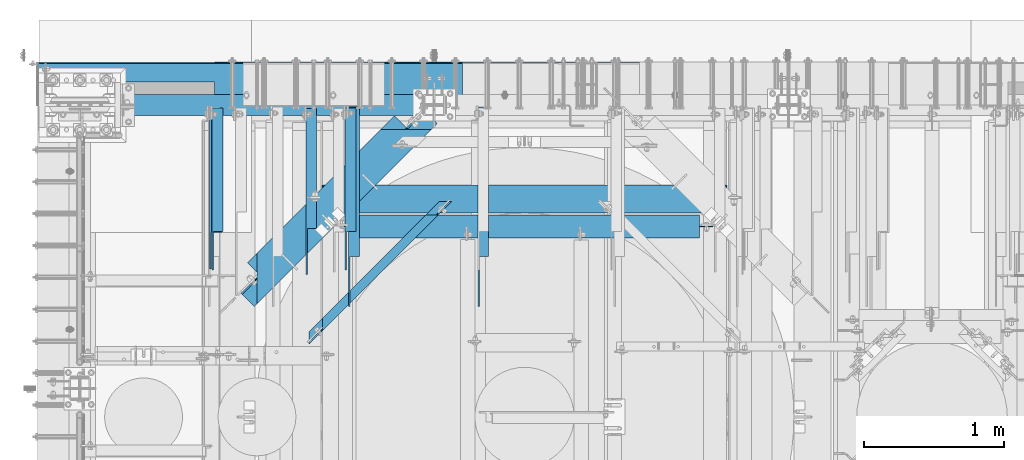
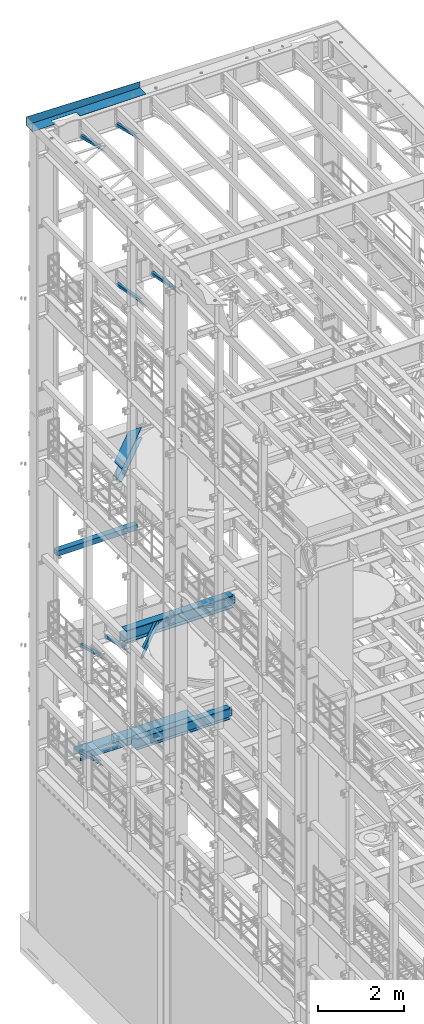
# One storey, part 1058 of 1876: 14 beams, 14 elements without a shape of their own.
"""IFC2X3 building model written with IfcOpenShell, lengths in millimetres."""

from ifc_helpers import new_model, si_unit, frame, origin_with_axes, place, context, subcontext, project, spatial, faceted_brep, material, type_object, element, aggregate, save


model = new_model("IFC2X3")

# Units and contexts
model_context = context("Model", 3, precision=1e-05, world=origin_with_axes())
body_context = subcontext(model_context, "Body", "Model", "MODEL_VIEW")
ifc_project = project(units=[si_unit("LENGTHUNIT", "METRE", prefix="MILLI"), si_unit("AREAUNIT", "SQUARE_METRE"), si_unit("VOLUMEUNIT", "CUBIC_METRE"), si_unit("MASSUNIT", "GRAM", prefix="KILO"), si_unit("TIMEUNIT", "SECOND"), si_unit("PLANEANGLEUNIT", "RADIAN"), si_unit("SOLIDANGLEUNIT", "STERADIAN"), si_unit("THERMODYNAMICTEMPERATUREUNIT", "DEGREE_CELSIUS"), si_unit("LUMINOUSINTENSITYUNIT", "LUMEN")], contexts=[model_context])

# Site, building, storey
site_placement = place(None, origin_with_axes())
site = spatial("IfcSite", under=ifc_project, at=site_placement, CompositionType="ELEMENT")
building_placement = place(site_placement, origin_with_axes())
building = spatial("IfcBuilding", under=site, at=building_placement, Name="Undefined", CompositionType="ELEMENT")
storey_placement = place(building_placement, origin_with_axes())
storey = spatial("IfcBuildingStorey", under=building, at=storey_placement, Name="Undefined", CompositionType="ELEMENT", Elevation=0.0)

# Assembly, beam
assembly_1_placement = place(storey_placement, origin_with_axes())
assembly_1 = element("IfcElementAssembly", 1, at=assembly_1_placement, inside=storey, Name="FRAME", AssemblyPlace="NOTDEFINED", PredefinedType="RIGID_FRAME")
ifc_material_1 = material()
beam_type_1 = type_object("IfcBeamType", Name="HSS6X6X3/8", PredefinedType="NOTDEFINED")
beam_1_placement = place(assembly_1_placement, frame((304.8, 13716.0, 10420.35), z_axis=(0.0, 1.0, 0.0), x_axis=(1.0, 0.0, 0.0)))
beam_1 = element("IfcBeam", 2, at=beam_1_placement, type_object=beam_type_1, material=ifc_material_1, Name="BEAM", ObjectType="HSS6X6X3/8", context=body_context, shape_type="Brep", body=[
    faceted_brep([(9.52500000000168, 66.6749999999993, -66.6750000000002), (9.52500000000168, -66.6749999999993, -66.6750000000002), (2159.0, -66.6750000000002, -66.6749999999993), (2159.0, 66.6750000000002, -66.6749999999993), (9.52500000000168, -66.6749999999993, 66.6750000000002), (2159.0, -66.6750000000002, 66.6749999999993), (9.52500000000168, 66.6749999999993, 66.6750000000002), (2159.0, 66.6750000000002, 66.6749999999993), (9.52500000000168, 76.2000000000007, -76.1999999999998), (9.52500000000168, 76.2000000000007, 76.1999999999998), (2159.0, 76.1999999999998, 76.2000000000007), (2159.0, 76.1999999999998, -76.2000000000007), (9.52500000000168, -76.2000000000007, 76.1999999999998), (2159.0, -76.1999999999998, 76.2000000000007), (9.52500000000168, -76.2000000000007, -76.1999999999998), (2159.0, -76.1999999999998, -76.2000000000007)], [[[0, 1, 2, 3]], [[1, 4, 5, 2]], [[4, 6, 7, 5]], [[6, 0, 3, 7]], [[8, 9, 10, 11]], [[9, 12, 13, 10]], [[12, 14, 15, 13]], [[14, 8, 11, 15]], [[13, 15, 11, 10], [5, 7, 3, 2]], [[14, 12, 9, 8], [6, 4, 1, 0]]]),
])
aggregate(assembly_1, [beam_1])

assembly_2_placement = place(storey_placement, origin_with_axes())
assembly_2 = element("IfcElementAssembly", 3, at=assembly_2_placement, inside=storey, AssemblyPlace="NOTDEFINED", PredefinedType="RIGID_FRAME")
ifc_material_2 = material(Name="STEEL/A36")
beam_type_2 = type_object("IfcBeamType", Name="L3X3X3/8", PredefinedType="NOTDEFINED")
beam_2_placement = place(assembly_2_placement, frame((968.375000095368, 12830.5843372416, 4789.15168871848), z_axis=(1.0, 0.0, 0.0), x_axis=(0.0, 0.967147277703794, -0.254216724922142)))
beam_2 = element("IfcBeam", 4, at=beam_2_placement, type_object=beam_type_2, material=ifc_material_2, ObjectType="L3X3X3/8", context=body_context, shape_type="Brep", body=[
    faceted_brep([(0.0, 38.1000000000004, -38.1), (0.0, 38.1000000000004, 38.1), (881.684520949349, 38.1000000001804, 38.1000000000004), (881.684520949349, 38.1000000001804, -38.1000000000004), (-36.2371036914428, 28.5749999999935, 38.1000000000004), (881.696433462228, 28.5750000001808, 38.1000000000004), (-36.2371036914428, 28.5749999999935, -28.5749999999998), (881.696433462228, 28.5750000001808, -28.5749999999998), (-289.896829504256, -38.1000000000595, -28.5749999999998), (881.779821052378, -38.0999999998203, -28.5749999999998), (-289.896829504256, -38.1000000000595, -38.1000000000004), (881.779821052378, -38.0999999998203, -38.1000000000004)], [[[0, 1, 2, 3]], [[1, 4, 5, 2]], [[4, 6, 7, 5]], [[6, 8, 9, 7]], [[8, 10, 11, 9]], [[10, 0, 3, 11]], [[5, 7, 9, 11, 3, 2]], [[10, 8, 6, 4, 1, 0]]]),
])
aggregate(assembly_2, [beam_2])

assembly_3_placement = place(storey_placement, origin_with_axes())
assembly_3 = element("IfcElementAssembly", 5, at=assembly_3_placement, inside=storey, AssemblyPlace="NOTDEFINED", PredefinedType="RIGID_FRAME")
beam_3_placement = place(assembly_3_placement, frame((1939.925, 12840.8509533049, 22213.431722183), z_axis=(1.0, 0.0, 0.0), x_axis=(0.0, 0.970296005691371, -0.241920774923053)))
beam_3 = element("IfcBeam", 6, at=beam_3_placement, type_object=beam_type_2, material=ifc_material_2, ObjectType="L3X3X3/8", context=body_context, shape_type="Brep", body=[
    faceted_brep([(0.0, 38.1000000000004, -38.1), (0.0, 38.1000000000004, 38.1), (871.989692018896, 38.1000000003733, 38.1000000000004), (871.989692018896, 38.1000000003733, -38.1000000000004), (-38.2028763666676, 28.5750000000298, 38.1000000000004), (871.9896920189, 28.5750000003572, 38.1000000000004), (-38.2028763666676, 28.5750000000298, -28.5749999999998), (871.9896920189, 28.5750000003572, -28.5749999999998), (-305.623010913256, -38.1000000001623, -28.5749999999998), (871.989692018928, -38.0999999997366, -28.5749999999998), (-305.623010913256, -38.1000000001623, -38.1000000000004), (871.989692018928, -38.0999999997366, -38.1000000000004)], [[[0, 1, 2, 3]], [[1, 4, 5, 2]], [[4, 6, 7, 5]], [[6, 8, 9, 7]], [[8, 10, 11, 9]], [[10, 0, 3, 11]], [[5, 7, 9, 11, 3, 2]], [[10, 8, 6, 4, 1, 0]]]),
])
aggregate(assembly_3, [beam_3])

assembly_4_placement = place(storey_placement, origin_with_axes())
assembly_4 = element("IfcElementAssembly", 7, at=assembly_4_placement, inside=storey, AssemblyPlace="NOTDEFINED", PredefinedType="RIGID_FRAME")
beam_4_placement = place(assembly_4_placement, frame((987.425, 12840.8509533049, 22213.431722183), z_axis=(1.0, 0.0, 0.0), x_axis=(0.0, 0.970296005691371, -0.241920774923053)))
beam_4 = element("IfcBeam", 8, at=beam_4_placement, type_object=beam_type_2, material=ifc_material_2, ObjectType="L3X3X3/8", context=body_context, shape_type="Brep", body=[
    faceted_brep([(0.0, 38.1000000000004, -38.1), (0.0, 38.1000000000004, 38.1), (871.989692018896, 38.1000000003733, 38.1000000000004), (871.989692018896, 38.1000000003733, -38.1000000000004), (-38.2028763666676, 28.5750000000298, 38.1000000000004), (871.9896920189, 28.5750000003572, 38.1000000000004), (-38.2028763666676, 28.5750000000298, -28.5749999999998), (871.9896920189, 28.5750000003572, -28.5749999999998), (-305.623010913256, -38.1000000001623, -28.5749999999998), (871.989692018928, -38.0999999997366, -28.5749999999998), (-305.623010913256, -38.1000000001623, -38.1000000000004), (871.989692018928, -38.0999999997366, -38.1000000000004)], [[[0, 1, 2, 3]], [[1, 4, 5, 2]], [[4, 6, 7, 5]], [[6, 8, 9, 7]], [[8, 10, 11, 9]], [[10, 0, 3, 11]], [[5, 7, 9, 11, 3, 2]], [[10, 8, 6, 4, 1, 0]]]),
])
aggregate(assembly_4, [beam_4])

assembly_5_placement = place(storey_placement, origin_with_axes())
assembly_5 = element("IfcElementAssembly", 9, at=assembly_5_placement, inside=storey, AssemblyPlace="NOTDEFINED", PredefinedType="RIGID_FRAME")
beam_5_placement = place(assembly_5_placement, frame((1659.73125, 12872.1857065717, 7766.82651976129), z_axis=(1.0, 0.0, 0.0), x_axis=(0.0, 0.979618903835331, -0.200865136966236)))
beam_5 = element("IfcBeam", 10, at=beam_5_placement, type_object=beam_type_2, material=ifc_material_2, ObjectType="L3X3X3/8", context=body_context, shape_type="Brep", body=[
    faceted_brep([(0.0, 38.1000000000004, -38.1), (0.0, 38.1000000000004, 38.1), (830.060116754295, 38.1000000001277, 38.0999999999999), (830.060116754295, 38.1000000001277, -38.0999999999999), (-46.4534075084157, 28.5749999999953, 38.0999999999999), (830.060116754288, 28.5750000001281, 38.0999999999999), (-46.4534075084157, 28.5749999999953, -28.575), (830.060116754288, 28.5750000001281, -28.575), (-371.627259972192, -38.1000000000549, -28.575), (830.060116754226, -38.0999999998749, -28.575), (-371.627259972192, -38.1000000000549, -38.0999999999999), (830.060116754226, -38.0999999998749, -38.0999999999999)], [[[0, 1, 2, 3]], [[1, 4, 5, 2]], [[4, 6, 7, 5]], [[6, 8, 9, 7]], [[8, 10, 11, 9]], [[10, 0, 3, 11]], [[5, 7, 9, 11, 3, 2]], [[10, 8, 6, 4, 1, 0]]]),
])
aggregate(assembly_5, [beam_5])

assembly_6_placement = place(storey_placement, origin_with_axes())
assembly_6 = element("IfcElementAssembly", 11, at=assembly_6_placement, inside=storey, AssemblyPlace="NOTDEFINED", PredefinedType="RIGID_FRAME")
beam_6_placement = place(assembly_6_placement, frame((981.075, 12830.5843372416, 7811.75168871848), z_axis=(1.0, 0.0, 0.0), x_axis=(0.0, 0.967147277703794, -0.254216724922142)))
beam_6 = element("IfcBeam", 12, at=beam_6_placement, type_object=beam_type_2, material=ifc_material_2, ObjectType="L3X3X3/8", context=body_context, shape_type="Brep", body=[
    faceted_brep([(0.0, 38.1000000000004, -38.1), (0.0, 38.1000000000004, 38.1), (881.684520949349, 38.1000000001804, 38.1000000000004), (881.684520949349, 38.1000000001804, -38.1000000000004), (-36.2371036914428, 28.5749999999935, 38.1000000000004), (881.696433462228, 28.5750000001808, 38.1000000000004), (-36.2371036914428, 28.5749999999935, -28.5749999999998), (881.696433462228, 28.5750000001808, -28.5749999999998), (-289.896829504256, -38.1000000000595, -28.5749999999998), (881.779821052378, -38.0999999998203, -28.5749999999998), (-289.896829504256, -38.1000000000595, -38.1000000000004), (881.779821052378, -38.0999999998203, -38.1000000000004)], [[[0, 1, 2, 3]], [[1, 4, 5, 2]], [[4, 6, 7, 5]], [[6, 8, 9, 7]], [[8, 10, 11, 9]], [[10, 0, 3, 11]], [[5, 7, 9, 11, 3, 2]], [[10, 8, 6, 4, 1, 0]]]),
])
aggregate(assembly_6, [beam_6])

assembly_7_placement = place(storey_placement, origin_with_axes())
assembly_7 = element("IfcElementAssembly", 13, at=assembly_7_placement, inside=storey, AssemblyPlace="NOTDEFINED", PredefinedType="RIGID_FRAME")
beam_7_placement = place(assembly_7_placement, frame((2892.425, 12478.7701585775, 17678.0584984364), z_axis=(1.0, 0.0, 0.0), x_axis=(0.0, 0.982729825630071, -0.185046182930343)))
beam_7 = element("IfcBeam", 14, at=beam_7_placement, type_object=beam_type_2, material=ifc_material_2, ObjectType="L3X3X3/8", context=body_context, shape_type="Brep", body=[
    faceted_brep([(200.493218531883, 38.099999999944, -38.1000000000004), (200.493218531883, 38.099999999944, 38.1000000000004), (1239.09835784596, 38.0999999993655, 38.1000000000004), (1239.09835784596, 38.0999999993655, -38.1000000000004), (149.908540475497, 28.5749999999571, 38.1000000000004), (1239.09863171315, 28.5749999993495, 38.1000000000004), (149.908540475497, 28.5749999999571, -28.5749999999998), (1239.09863171315, 28.5749999993495, -28.5749999999998), (-204.184205919202, -38.0999999999367, -28.5749999999998), (1239.10054878342, -38.1000000007407, -28.5749999999998), (-204.184205919202, -38.0999999999367, -38.1000000000004), (1239.10054878342, -38.1000000007407, -38.1000000000004)], [[[0, 1, 2, 3]], [[1, 4, 5, 2]], [[4, 6, 7, 5]], [[6, 8, 9, 7]], [[8, 10, 11, 9]], [[10, 0, 3, 11]], [[5, 7, 9, 11, 3, 2]], [[10, 8, 6, 4, 1, 0]]]),
])
aggregate(assembly_7, [beam_7])

assembly_8_placement = place(storey_placement, origin_with_axes())
assembly_8 = element("IfcElementAssembly", 15, at=assembly_8_placement, inside=storey, AssemblyPlace="NOTDEFINED", PredefinedType="RIGID_FRAME")
beam_8_placement = place(assembly_8_placement, frame((1965.325, 12478.7701585775, 17678.0584984364), z_axis=(1.0, 0.0, 0.0), x_axis=(0.0, 0.982729825630071, -0.185046182930343)))
beam_8 = element("IfcBeam", 16, at=beam_8_placement, type_object=beam_type_2, material=ifc_material_2, ObjectType="L3X3X3/8", context=body_context, shape_type="Brep", body=[
    faceted_brep([(200.493218531883, 38.099999999944, -38.1000000000004), (200.493218531883, 38.099999999944, 38.1000000000004), (1239.09835784596, 38.0999999993655, 38.1000000000004), (1239.09835784596, 38.0999999993655, -38.1000000000004), (149.908540475497, 28.5749999999571, 38.1000000000004), (1239.09863171315, 28.5749999993495, 38.1000000000004), (149.908540475497, 28.5749999999571, -28.5749999999998), (1239.09863171315, 28.5749999993495, -28.5749999999998), (-204.184205919202, -38.0999999999367, -28.5749999999998), (1239.10054878342, -38.1000000007407, -28.5749999999998), (-204.184205919202, -38.0999999999367, -38.1000000000004), (1239.10054878342, -38.1000000007407, -38.1000000000004)], [[[0, 1, 2, 3]], [[1, 4, 5, 2]], [[4, 6, 7, 5]], [[6, 8, 9, 7]], [[8, 10, 11, 9]], [[10, 0, 3, 11]], [[5, 7, 9, 11, 3, 2]], [[10, 8, 6, 4, 1, 0]]]),
])
aggregate(assembly_8, [beam_8])

assembly_9_placement = place(storey_placement, origin_with_axes())
assembly_9 = element("IfcElementAssembly", 17, at=assembly_9_placement, inside=storey, Name="BENT PLATE", AssemblyPlace="NOTDEFINED", PredefinedType="RIGID_FRAME")
beam_type_3 = type_object("IfcBeamType", PredefinedType="NOTDEFINED")
beam_9_placement = place(assembly_9_placement, frame((1219.2, 13715.9999771422, 22558.3750000001), z_axis=(1.0, 0.0, 0.0), x_axis=(0.0, 0.999999999968684, -7.91400000071008e-06)))
beam_9 = element("IfcBeam", 18, at=beam_9_placement, type_object=beam_type_3, material=ifc_material_2, Name="BENT PLATE", context=body_context, shape_type="Brep", body=[
    faceted_brep([(165.100051822586, -3.17500005137117, -927.100027859217), (165.100006108936, 3.17499994863465, -927.100027859217), (9.91349224932492e-10, 3.17500000000291, -927.100027859217), (-9.85892256721854e-10, -3.17500000000291, -927.100027859217), (165.100051822586, -3.17500005137117, -253.999991238123), (165.100006108936, 3.17499994863465, -253.999991238123), (-9.85892256721854e-10, -3.17500000000291, -253.999991238123), (9.91349224932492e-10, 3.17500000000291, -253.999991238123), (298.449951181141, 3.17499990714714, -1524.0), (298.449951181141, 3.17499990714714, 1524.0), (298.448968570774, 173.680054702585, 1524.0), (298.448604036646, 236.934945778212, -1524.0), (-9.88620740827173e-10, 3.17500000000291, 1524.0), (9.877112461254e-10, -3.17499999999563, 1524.0), (304.799984389467, -3.1750000948341, 1524.0), (304.79896857062, 173.680100416237, 1524.0), (304.799984389467, -3.1750000948341, -1524.0), (304.798604036541, 236.934982372881, -1524.0), (9.877112461254e-10, -3.17499999999563, -1524.0), (-9.88620740827173e-10, 3.17500000000291, -1524.0)], [[[0, 1, 2, 3]], [[4, 5, 1, 0]], [[6, 7, 5, 4]], [[8, 9, 10, 11]], [[9, 12, 13, 14, 15, 10]], [[14, 16, 17, 15]], [[11, 10, 15, 17]], [[16, 18, 19, 8, 11, 17]], [[19, 18, 3, 2]], [[12, 9, 8, 19, 2, 1, 5, 7]], [[13, 12, 7, 6]], [[3, 18, 16, 14, 13, 6, 4, 0]]]),
])
aggregate(assembly_9, [beam_9])

assembly_10_placement = place(storey_placement, origin_with_axes())
assembly_10 = element("IfcElementAssembly", 19, at=assembly_10_placement, inside=storey, Name="BENT PLATE", AssemblyPlace="NOTDEFINED", PredefinedType="RIGID_FRAME")
beam_type_4 = type_object("IfcBeamType", PredefinedType="NOTDEFINED")
beam_10_placement = place(assembly_10_placement, frame((2489.20001220703, 14017.625, 4279.90000305174), z_axis=(1.0, 0.0, 0.0), x_axis=(0.0, 0.0, 1.0)))
beam_10 = element("IfcBeam", 20, at=beam_10_placement, type_object=beam_type_4, material=ifc_material_2, Name="BENT PLATE", context=body_context, shape_type="Brep", body=[
    faceted_brep([(0.0, -6.35000000000036, -1524.0), (0.0, -6.35000000000036, 1524.0), (0.0, 6.35000000000036, 1524.0), (0.0, 6.35000000000036, -1524.0), (190.499996948255, 6.35000000000218, 1524.0), (190.499996948255, 6.35000000000218, -1524.0), (203.199996948256, -6.34999999999854, -1524.0), (203.199996948256, -6.34999999999854, 1524.0), (190.499996948255, 303.212481689452, 1524.0), (190.499996948255, 303.212481689452, -1524.0), (203.199996948256, 315.912481689453, -1524.0), (203.199996948256, 315.912481689453, 1524.0), (2.81943357549608e-11, 303.212481689452, 1524.0), (2.81943357549608e-11, 303.212481689452, -1524.0), (2.81943357549608e-11, 315.912481689453, 1524.0), (2.81943357549608e-11, 315.912481689453, -1524.0)], [[[0, 1, 2, 3]], [[3, 2, 4, 5]], [[1, 0, 6, 7]], [[5, 4, 8, 9]], [[7, 6, 10, 11]], [[9, 8, 12, 13]], [[8, 4, 2, 1, 7, 11, 14, 12]], [[11, 10, 15, 14]], [[10, 6, 0, 3, 5, 9, 13, 15]], [[14, 15, 13, 12]]]),
])
aggregate(assembly_10, [beam_10])

assembly_11_placement = place(storey_placement, origin_with_axes())
assembly_11 = element("IfcElementAssembly", 21, at=assembly_11_placement, inside=storey, Name="BEAM", AssemblyPlace="NOTDEFINED", PredefinedType="RIGID_FRAME")
beam_type_5 = type_object("IfcBeamType", Name="C8X18.75", PredefinedType="NOTDEFINED")
beam_11_placement = place(assembly_11_placement, frame((2619.48116020886, 13023.0455033164, 8051.8), z_axis=(0.0, 0.0, 1.0), x_axis=(-0.707305809668414, -0.706907696668603, 0.0)))
beam_11 = element("IfcBeam", 22, at=beam_11_placement, type_object=beam_type_5, material=ifc_material_2, Name="BEAM", ObjectType="C8X18.75", context=body_context, shape_type="Brep", body=[
    faceted_brep([(27.2612858286848, -31.7499999999927, -97.3645500000002), (27.2612858286848, -31.7499999999927, -101.6), (1349.86603784282, -31.749999999598, -101.6), (1349.86603784282, -31.749999999598, -97.3645500000002), (-36.2744758069912, 31.7499999999918, -101.6), (1413.33029633597, 31.7500000004247, -101.6), (1400.63744463734, 19.0500000004204, -88.9012700000003), (1413.33029633597, 31.7500000004247, 73.0250000000033), (1400.63744463734, 19.0500000004204, 73.0250000000033), (-23.567323479856, 19.0499999999947, -88.9012700000003), (-23.567323479856, 19.0499999999947, 73.0249999980779), (-36.2744758069912, 31.7499999999918, 73.0249999980779), (96.5774267699799, 19.0500000000302, 73.0249999980779), (83.8702744428447, 31.7500000000282, 73.0249999980779), (103.45255281678, 19.0500000000329, 73.9917299206654), (90.7454004896463, 31.75000000003, 73.9917299206654), (109.281003246128, 19.0500000000338, 76.7447438211439), (96.5738509189905, 31.7500000000318, 76.7447438211439), (113.175449315189, 19.0500000000357, 80.8649202892975), (100.468296988052, 31.7500000000327, 80.8649202892975), (114.542996913191, 19.0500000000366, 85.724999807343), (101.835844586056, 31.7500000000327, 85.724999807343), (1275.29771249639, 31.7500000003829, 101.6), (1275.29771249644, 31.7500000003838, 85.7249998092684), (1276.66449035882, 31.7500000003838, 80.8649202912229), (1280.55674440629, 31.7500000003847, 76.7447438230693), (1286.38191424349, 31.7500000003865, 73.9917299225908), (1293.253170568, 31.7500000003884, 73.0250000000033), (101.83584458595, 31.7500000000327, 101.6), (1211.83345400329, -31.7499999996398, 101.6), (165.371606221586, -31.7499999999518, 101.6), (1211.83345400329, -31.7499999996398, 97.3645500000002), (165.371606221586, -31.7499999999518, 97.3645500000002), (1262.60486079777, 19.0500000003785, 88.9012700000003), (114.542996913078, 19.0500000000366, 88.9012700000003), (1280.56031886937, 19.050000000384, 73.0250000000033), (1273.68906254486, 19.0500000003822, 73.9917299225908), (1267.86389270766, 19.0500000003813, 76.7447438230693), (1263.97163866019, 19.0500000003794, 80.8649202912229), (1262.60486079781, 19.0500000003785, 85.7249998092684)], [[[0, 1, 2, 3]], [[1, 4, 5, 2]], [[6, 3, 2, 5, 7, 8]], [[9, 0, 3, 6]], [[4, 1, 0, 9, 10, 11]], [[12, 13, 11, 10]], [[14, 15, 13, 12]], [[16, 17, 15, 14]], [[18, 19, 17, 16]], [[20, 21, 19, 18]], [[22, 23, 24, 25, 26, 27, 7, 5, 4, 11, 13, 15, 17, 19, 21, 28]], [[29, 22, 28, 30]], [[31, 29, 30, 32]], [[33, 31, 32, 34]], [[30, 28, 21, 20, 34, 32]], [[18, 16, 14, 12, 10, 9, 6, 8, 35, 36, 37, 38, 39, 33, 34, 20]], [[7, 27, 35, 8]], [[26, 36, 35, 27]], [[25, 37, 36, 26]], [[24, 38, 37, 25]], [[23, 39, 38, 24]], [[22, 29, 31, 33, 39, 23]]]),
])
aggregate(assembly_11, [beam_11])

assembly_12_placement = place(storey_placement, origin_with_axes())
assembly_12 = element("IfcElementAssembly", 23, at=assembly_12_placement, inside=storey, Name="BEAM", AssemblyPlace="NOTDEFINED", PredefinedType="RIGID_FRAME")
ifc_material_3 = material(Name="STEEL/A992")
beam_type_6 = type_object("IfcBeamType", Name="W12X30", PredefinedType="NOTDEFINED")
beam_12_placement = place(assembly_12_placement, frame((1866.9, 12846.0499999996, 4973.6375), z_axis=(0.0, 0.0, 1.0), x_axis=(1.0, 0.0, 0.0)))
beam_12 = element("IfcBeam", 24, at=beam_12_placement, type_object=beam_type_6, material=ifc_material_3, Name="BEAM", ObjectType="W12X30", context=body_context, shape_type="Brep", body=[
    faceted_brep([(-28.5750000000032, -3.17499999999927, -131.762499999999), (-28.5750000000032, 3.17499999999927, -131.762499999999), (53.9750001907323, 3.17499999999927, -131.762499999999), (53.9750001907323, -3.17499999999927, -131.762499999999), (58.8350797087778, 3.17499999999927, -132.729229922586), (58.8350797087778, -3.17499999999927, -132.729229922586), (62.9552561769315, 3.17499999999927, -135.482243823065), (62.9552561769315, -3.17499999999927, -135.482243823065), (65.7082700774097, 3.17499999999927, -139.602420291219), (65.7082700774097, -3.17499999999927, -139.602420291219), (66.6749999999975, -3.17499999999927, -144.462499809264), (66.6749999999975, 3.17499999999927, -144.462499809264), (66.6750000000002, 3.17500000000018, -146.049999999999), (66.6749999999975, 82.5499999999993, -146.05), (66.6749999999975, 82.5499999999993, -157.1625), (66.6749999999975, -82.5499999999993, -157.1625), (66.6749999999975, -82.5499999999993, -146.05), (66.6750000000002, -3.17500000000018, -146.049999999999), (66.6750000000002, 3.17500000000018, 146.049999999999), (66.6749999999975, 82.5499999999993, 146.05), (2574.925, 82.5499999999993, 146.05), (2574.925, 3.17499999999927, 146.05), (53.9750001907323, -3.17499999999927, 131.762500000001), (53.9750001907323, 3.17499999999927, 131.762500000001), (-28.5750000000032, 3.17499999999927, 131.762500000001), (-28.5750000000032, -3.17499999999927, 131.762500000001), (58.8350797087778, -3.17499999999927, 132.729229922588), (58.8350797087778, 3.17499999999927, 132.729229922588), (62.9552561769315, -3.17499999999927, 135.482243823067), (62.9552561769315, 3.17499999999927, 135.482243823067), (65.7082700774097, -3.17499999999927, 139.60242029122), (65.7082700774097, 3.17499999999927, 139.60242029122), (66.6749999999975, -3.17499999999927, 144.462499809266), (66.6749999999975, 3.17499999999927, 144.462499809266), (66.6749999999975, 82.5499999999993, 157.1625), (66.6749999999975, -82.5499999999993, 157.1625), (2574.925, -82.5499999999993, 157.1625), (2574.925, 82.5499999999993, 157.1625), (66.6749999999975, -82.5499999999993, 146.05), (2574.925, -82.5499999999993, 146.05), (66.6750000000002, -3.17500000000018, 146.049999999999), (2574.925, -3.17499999999927, 146.05), (2574.925, -3.17499999999927, 144.462499809266), (2574.925, 3.17499999999927, 144.462499809266), (2575.89172992259, -3.17499999999927, 139.60242029122), (2575.89172992259, 3.17499999999927, 139.60242029122), (2578.64474382307, -3.17499999999927, 135.482243823067), (2578.64474382307, 3.17499999999927, 135.482243823067), (2582.76492029122, -3.17499999999927, 132.729229922588), (2582.76492029122, 3.17499999999927, 132.729229922588), (2587.62499980926, -3.17499999999927, 131.762500000001), (2587.62499980926, 3.17499999999927, 131.762500000001), (2670.175, -3.17499999999927, 131.762500000001), (2670.175, 3.17499999999927, 131.762500000001), (2670.175, -3.17499999999927, -131.762499999999), (2670.175, 3.17499999999927, -131.762499999999), (2587.62499980927, -3.17499999999927, -131.762499999999), (2587.62499980927, 3.17499999999927, -131.762499999999), (2582.76492029122, -3.17499999999927, -132.729229922586), (2582.76492029122, 3.17499999999927, -132.729229922586), (2578.64474382307, -3.17499999999927, -135.482243823065), (2578.64474382307, 3.17499999999927, -135.482243823065), (2575.89172992259, -3.17499999999927, -139.602420291219), (2575.89172992259, 3.17499999999927, -139.602420291219), (2574.925, -3.17499999999927, -144.462499809264), (2574.925, 3.17499999999927, -144.462499809264), (2574.925, -3.17499999999927, -146.05), (2574.925, -82.5499999999993, -146.05), (2574.925, -82.5499999999993, -157.1625), (2574.925, 82.5499999999993, -157.1625), (2574.925, 82.5499999999993, -146.05), (2574.925, 3.17499999999927, -146.05)], [[[0, 1, 2, 3]], [[3, 2, 4, 5]], [[5, 4, 6, 7]], [[7, 6, 8, 9]], [[10, 11, 12, 13, 14, 15, 16, 17]], [[9, 8, 11, 10]], [[18, 19, 20, 21]], [[22, 23, 24, 25]], [[26, 27, 23, 22]], [[28, 29, 27, 26]], [[30, 31, 29, 28]], [[32, 33, 31, 30]], [[34, 35, 36, 37]], [[35, 38, 39, 36]], [[38, 40, 41, 39]], [[35, 34, 19, 18, 33, 32, 40, 38]], [[19, 34, 37, 20]], [[36, 39, 41, 42, 43, 21, 20, 37]], [[44, 45, 43, 42]], [[46, 47, 45, 44]], [[48, 49, 47, 46]], [[50, 51, 49, 48]], [[52, 53, 51, 50]], [[53, 52, 54, 55]], [[54, 56, 57, 55]], [[58, 59, 57, 56]], [[60, 61, 59, 58]], [[62, 63, 61, 60]], [[64, 65, 63, 62]], [[66, 67, 68, 69, 70, 71, 65, 64]], [[17, 16, 67, 66]], [[16, 15, 68, 67]], [[15, 14, 69, 68]], [[14, 13, 70, 69]], [[13, 12, 71, 70]], [[59, 61, 63, 65, 71, 12, 11, 8, 6, 4, 2, 1, 24, 23, 27, 29, 31, 33, 18, 21, 43, 45, 47, 49, 51, 53, 55, 57]], [[25, 24, 1, 0]], [[52, 50, 48, 46, 44, 42, 41, 40, 32, 30, 28, 26, 22, 25, 0, 3, 5, 7, 9, 10, 17, 66, 64, 62, 60, 58, 56, 54]]]),
])
aggregate(assembly_12, [beam_12])

assembly_13_placement = place(storey_placement, origin_with_axes())
assembly_13 = element("IfcElementAssembly", 25, at=assembly_13_placement, inside=storey, Name="BEAM", AssemblyPlace="NOTDEFINED", PredefinedType="RIGID_FRAME")
beam_type_7 = type_object("IfcBeamType", Name="W14X48", PredefinedType="NOTDEFINED")
beam_13_placement = place(assembly_13_placement, frame((1225.55, 13042.9, 7978.775), z_axis=(0.0, 0.0, 1.0), x_axis=(1.0, 0.0, 0.0)))
beam_13 = element("IfcBeam", 26, at=beam_13_placement, type_object=beam_type_7, material=ifc_material_3, Name="BEAM", ObjectType="W14X48", context=body_context, shape_type="Brep", body=[
    faceted_brep([(3412.33125, -3.96875, -158.75), (3412.33125, -101.6, -158.75), (3412.33125, -101.6, -174.625), (3412.33125, 101.6, -174.625), (3412.33125, 101.6, -158.75), (3412.33125, 3.96875, -158.75), (3412.33125, 3.96875, -155.574999809265), (3412.33125, -3.96875, -155.574999809265), (3413.29797992259, 3.96875, -150.71492029122), (3413.29797992259, -3.96875, -150.71492029122), (3416.05099382307, 3.96875, -146.594743823066), (3416.05099382307, -3.96875, -146.594743823066), (3420.17117029122, 3.96875, -143.841729922588), (3420.17117029122, -3.96875, -143.841729922588), (3425.03124980926, 3.96875, -142.875), (3425.03124980926, -3.96875, -142.875), (3507.58125, -3.96875, -142.875), (3507.58125, 3.96875, -142.875), (3405.98125, 101.6, 158.75), (3405.98125, 3.96875, 158.75), (518.31875, 3.96875, 158.75), (518.31875, 101.6, 158.75), (511.96875, -3.96875, -155.574999809265), (511.96875, 3.96875, -155.574999809265), (511.96875, 3.96875, -158.75), (511.96875, 101.6, -158.75), (511.96875, 101.6, -174.625), (511.96875, -101.6, -174.625), (511.96875, -101.6, -158.75), (511.96875, -3.96875, -158.75), (511.002020077412, -3.96875, -150.71492029122), (511.002020077412, 3.96875, -150.71492029122), (508.249006176934, -3.96875, -146.594743823066), (508.249006176934, 3.96875, -146.594743823066), (504.12882970878, -3.96875, -143.841729922588), (504.12882970878, 3.96875, -143.841729922588), (499.268750190735, -3.96875, -142.875), (499.268750190735, 3.96875, -142.875), (416.71875, -3.96875, -142.875), (416.71875, 3.96875, -142.875), (416.71875, -3.96875, 142.875), (416.71875, 3.96875, 142.875), (505.618750190735, -3.96875, 142.875), (505.618750190735, 3.96875, 142.875), (510.47882970878, -3.96875, 143.841729922588), (510.47882970878, 3.96875, 143.841729922588), (514.599006176934, -3.96875, 146.594743823066), (514.599006176934, 3.96875, 146.594743823066), (517.352020077412, -3.96875, 150.71492029122), (517.352020077412, 3.96875, 150.71492029122), (518.31875, -3.96875, 155.574999809265), (518.31875, 3.96875, 155.574999809265), (518.31875, -101.6, 174.625), (518.31875, 101.6, 174.625), (518.31875, -3.96875, 158.75), (518.31875, -101.6, 158.75), (3405.98125, -3.96875, 158.75), (3405.98125, -101.6, 158.75), (3405.98125, -101.6, 174.625), (3405.98125, 101.6, 174.625), (3405.98125, -3.96875, 155.574999809265), (3405.98125, 3.96875, 155.574999809265), (3406.94797992259, -3.96875, 150.71492029122), (3406.94797992259, 3.96875, 150.71492029122), (3409.70099382307, -3.96875, 146.594743823066), (3409.70099382307, 3.96875, 146.594743823066), (3413.82117029122, -3.96875, 143.841729922588), (3413.82117029122, 3.96875, 143.841729922588), (3418.68124980926, -3.96875, 142.875), (3418.68124980926, 3.96875, 142.875), (3507.58125, -3.96875, 142.875), (3507.58125, 3.96875, 142.875)], [[[0, 1, 2, 3, 4, 5, 6, 7]], [[7, 6, 8, 9]], [[9, 8, 10, 11]], [[11, 10, 12, 13]], [[13, 12, 14, 15]], [[16, 15, 14, 17]], [[18, 19, 20, 21]], [[22, 23, 24, 25, 26, 27, 28, 29]], [[30, 31, 23, 22]], [[32, 33, 31, 30]], [[34, 35, 33, 32]], [[36, 37, 35, 34]], [[38, 39, 37, 36]], [[40, 41, 39, 38]], [[42, 43, 41, 40]], [[44, 45, 43, 42]], [[46, 47, 45, 44]], [[48, 49, 47, 46]], [[50, 51, 49, 48]], [[52, 53, 21, 20, 51, 50, 54, 55]], [[56, 57, 55, 54]], [[57, 58, 52, 55]], [[58, 59, 53, 52]], [[59, 18, 21, 53]], [[58, 57, 56, 60, 61, 19, 18, 59]], [[62, 63, 61, 60]], [[64, 65, 63, 62]], [[66, 67, 65, 64]], [[68, 69, 67, 66]], [[70, 71, 69, 68]], [[71, 70, 16, 17]], [[33, 35, 37, 39, 41, 43, 45, 47, 49, 51, 20, 19, 61, 63, 65, 67, 69, 71, 17, 14, 12, 10, 8, 6, 5, 24, 23, 31]], [[5, 4, 25, 24]], [[4, 3, 26, 25]], [[3, 2, 27, 26]], [[2, 1, 28, 27]], [[1, 0, 29, 28]], [[0, 7, 9, 11, 13, 15, 16, 70, 68, 66, 64, 62, 60, 56, 54, 50, 48, 46, 44, 42, 40, 38, 36, 34, 32, 30, 22, 29]]]),
])
aggregate(assembly_13, [beam_13])

assembly_14_placement = place(storey_placement, origin_with_axes())
assembly_14 = element("IfcElementAssembly", 27, at=assembly_14_placement, inside=storey, Name="BEAM", AssemblyPlace="NOTDEFINED", PredefinedType="RIGID_FRAME")
beam_type_8 = type_object("IfcBeamType", Name="W14X68", PredefinedType="NOTDEFINED")
beam_14_placement = place(assembly_14_placement, frame((1098.59673643742, 12301.4907731646, 13131.8), z_axis=(0.0, 0.0, 1.0), x_axis=(0.707106781186548, 0.707106781186547, 0.0)))
beam_14 = element("IfcBeam", 28, at=beam_14_placement, type_object=beam_type_8, material=ifc_material_3, Name="BEAM", ObjectType="W14X68", context=body_context, shape_type="Brep", body=[
    faceted_brep([(273.43519208884, 5.5562500936885, -158.75), (273.43519208884, 5.5562500936885, -177.799999999999), (266.291436373644, 5.55625008126299, -177.799999999999), (266.291436373644, 5.55625008126299, -158.75), (273.435192088818, 127.000000000045, -158.75), (273.435192088818, 127.000000000045, -177.799999999999), (1763.59876330014, 5.55625000028522, -158.75), (1763.59876330014, 5.55625000085274, -177.799999999999), (1763.59700340461, 127.000000000285, -177.799999999999), (1763.59700340461, 127.000000000285, -158.75), (1940.57180180113, -126.999999999688, -177.799999999999), (1940.57180180113, -126.999999999688, -158.75), (86.5061948690891, -126.999999999986, -158.75), (86.5061948690891, -126.999999999986, -177.799999999999), (1940.57213567631, -5.55691643019418, -177.799999999999), (1940.57213567998, -5.55624999968677, -158.75), (86.5061948691273, -5.55624999998599, -158.75), (1756.77227533717, -5.55624999971769, 158.75), (1878.21602533715, -126.999999999699, 158.75), (113.15576488176, -126.999999999982, 158.75), (234.59951488178, -5.55624999996144, 158.75), (1785.99281253889, 5.55625000028886, 114.299999999999), (1763.62028730957, 5.5562500002834, 114.299999999999), (1774.73278730957, -5.55624999971405, 114.299999999999), (1940.57180180529, -5.55624999968677, 114.299999999999), (1940.5718018053, 5.5562500003125, 114.299999999999), (1756.74709694094, 5.5562500002834, 115.266729922587), (1767.85959694094, -5.55624999971405, 115.266729922587), (1750.9202875003, 5.55625000028158, 118.019743823064), (1762.0327875003, -5.55624999971678, 118.019743823064), (1747.02693790485, 5.55625000028158, 122.139920291218), (1758.13943790484, -5.55624999971678, 122.139920291218), (1745.65977533717, 5.55625000028067, 126.999999809264), (1756.77227533717, -5.55624999971769, 126.999999809264), (1878.21602533715, -126.999999999699, 177.799999999999), (1756.77227533717, -5.55624999971769, 139.699996948239), (1745.65977533717, 5.55625000028067, 139.699996948239), (1745.65977533717, 5.55625000028067, 158.75), (1624.21602533719, 127.000000000262, 158.75), (1624.21602533719, 127.000000000262, 177.799999999999), (245.712014881781, 5.55625000003874, 158.75), (367.155764881803, 127.000000000061, 158.75), (367.155764881803, 127.000000000061, 177.799999999999), (113.15576488176, -126.999999999982, 177.799999999999), (245.712014881781, 5.55625000003965, 146.049999809266), (234.59951488178, -5.55624999996144, 146.049999809266), (244.68525326348, 5.55625000004056, 142.400000000171), (244.344852314105, 5.55625000004056, 141.189920291219), (233.232352314104, -5.55624999996235, 141.189920291219), (240.45150271865, 5.55625000003965, 137.069743823065), (229.339002718647, -5.55624999996326, 137.069743823065), (234.624693278018, 5.55625000003783, 134.316729922588), (223.512193278015, -5.55624999996508, 134.316729922588), (227.751502909387, 5.55625000003783, 133.35), (216.639002909384, -5.55624999996326, 133.35), (86.5061948691273, -5.55624999998599, 133.35), (1940.5718018053, 5.55625000042528, -177.799999999999), (1940.5718018053, 5.5562500003125, -158.75), (1785.99281253889, 5.55625000079817, -177.799999999999), (1785.99281253889, 5.55625000028886, -158.75), (86.3124665750765, 5.5562500000151, 133.35), (86.3124665750765, 5.5562500000151, -158.75), (86.3124665750765, 5.5562500000151, 130.915006484984), (86.3134243033055, 5.55720772824588, -177.799999999999)], [[[0, 1, 2, 3]], [[4, 5, 1, 0]], [[6, 7, 8, 9]], [[10, 11, 12, 13]], [[11, 10, 14, 15]], [[11, 15, 16, 12]], [[17, 18, 19, 20]], [[21, 22, 23, 24, 25]], [[23, 22, 26, 27]], [[27, 26, 28, 29]], [[29, 28, 30, 31]], [[31, 30, 32, 33]], [[34, 18, 17, 35, 33, 32, 36, 37, 38, 39]], [[38, 37, 40, 41]], [[39, 38, 41, 42]], [[34, 39, 42, 43]], [[18, 34, 43, 19]], [[42, 41, 40, 44, 45, 20, 19, 43]], [[46, 47, 48, 45, 44]], [[49, 50, 48, 47]], [[51, 52, 50, 49]], [[53, 54, 52, 51]], [[15, 24, 23, 27, 29, 31, 33, 35, 17, 20, 45, 48, 50, 52, 54, 55, 16]], [[14, 56, 57, 25, 24, 15]], [[58, 7, 6, 59, 57, 56]], [[60, 53, 51, 49, 47, 46, 44, 40, 37, 36, 32, 30, 28, 26, 22, 21, 25, 57, 59, 6, 0, 3, 61, 62]], [[54, 53, 60, 55]], [[62, 61, 63, 13, 12, 16, 55, 60]], [[3, 2, 63, 61]], [[8, 7, 58, 56, 14, 10, 13, 63, 2, 1, 5]], [[9, 8, 5, 4]], [[6, 9, 4, 0]]]),
])
aggregate(assembly_14, [beam_14])

save(model, "model.ifc")
